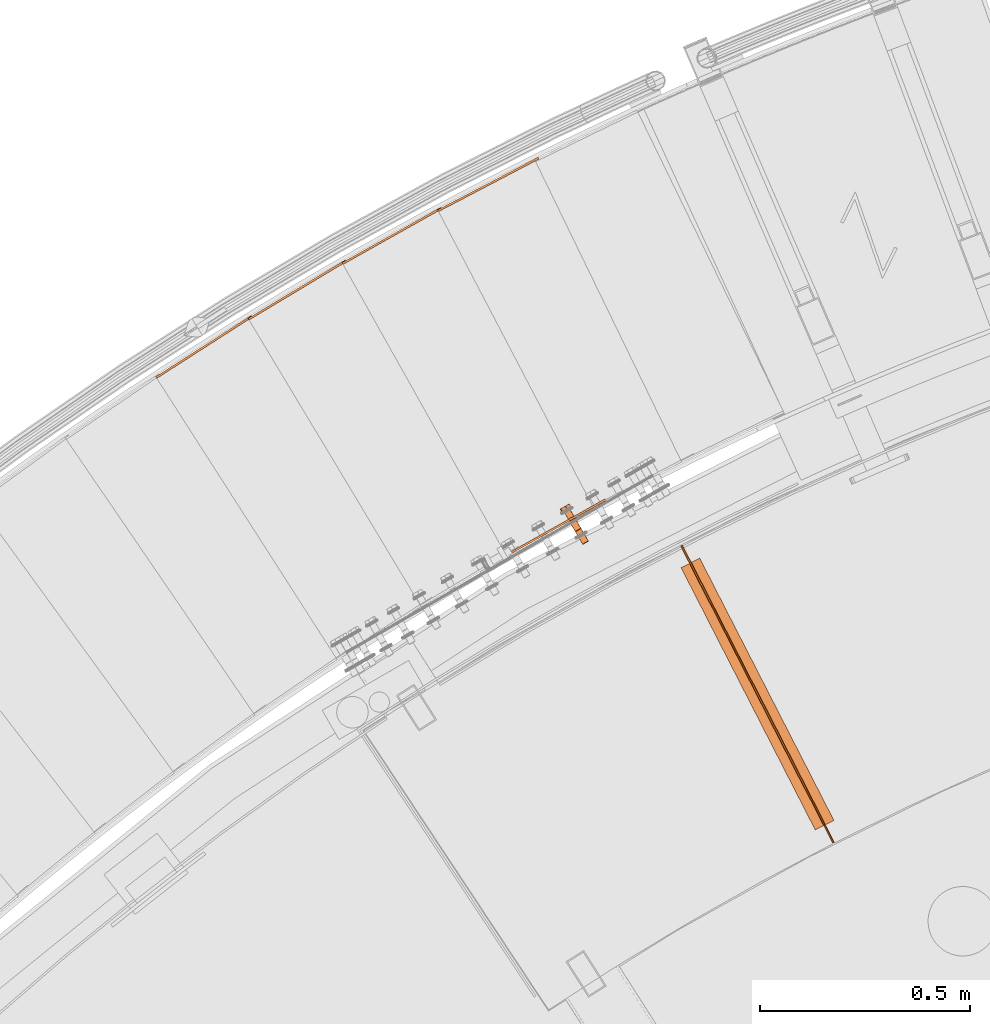
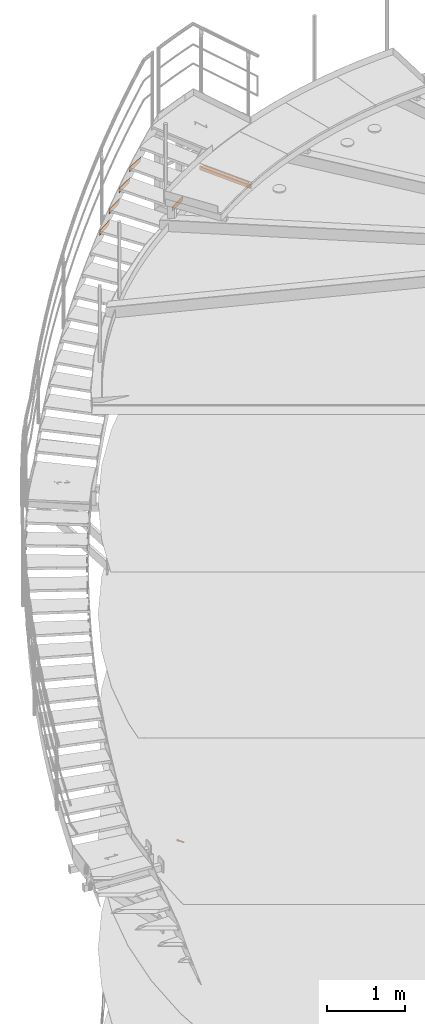
# One storey, part 80 of 126: 8 proxies.
"""IFC2X3 building model written with IfcOpenShell, lengths in millimetres."""

from ifc_helpers import new_model, si_unit, origin, origin_with_axes, place, context, project, spatial, faceted_brep, material, element, save


model = new_model("IFC2X3")

# Units and contexts
context_of_model_1 = context(None, 3, precision=0.1, world=origin())
context_of_model_2 = context(None, 3, precision=0.1, world=origin())
ifc_project = project(units=[si_unit("LENGTHUNIT", "METRE", prefix="MILLI"), si_unit("AREAUNIT", "SQUARE_METRE", prefix="CENTI"), si_unit("VOLUMEUNIT", "CUBIC_METRE", prefix="CENTI"), si_unit("MASSUNIT", "GRAM", prefix="KILO")], contexts=[context_of_model_1, context_of_model_2])

# Site, building, storey
site_placement = place(None, origin_with_axes())
site = spatial("IfcSite", under=ifc_project, at=site_placement, CompositionType="ELEMENT")
building_placement = place(site_placement, origin_with_axes())
building = spatial("IfcBuilding", under=site, at=building_placement, CompositionType="ELEMENT")
storey_placement = place(building_placement, origin_with_axes())
storey = spatial("IfcBuildingStorey", under=building, at=storey_placement, CompositionType="ELEMENT")

# Proxies
ifc_material_1 = material(Name="STAHL")
proxy_1_placement = place(storey_placement, origin_with_axes())
element("IfcBuildingElementProxy", 1, at=proxy_1_placement, inside=storey, material=ifc_material_1, Name="profile", context=context_of_model_2, shape_type="Brep", body=[
    faceted_brep([(4205.7, 14993.4, 508.9), (4207.3, 14994.3, 509.4), (4207.5, 14993.2, 510.4), (4206.1, 14992.4, 509.9), (4204.0, 14992.4, 508.8), (4204.7, 14991.5, 509.9), (4202.4, 14991.5, 509.2), (4203.2, 14990.7, 510.2), (4200.9, 14990.6, 510.1), (4201.9, 14990.0, 511.0), (4199.6, 14989.9, 511.3), (4200.8, 14989.3, 512.0), (4198.6, 14989.3, 512.8), (4200.0, 14988.8, 513.4), (4198.0, 14988.9, 514.6), (4199.4, 14988.5, 514.9), (4197.7, 14988.8, 516.5), (4199.2, 14988.4, 516.6), (4197.9, 14988.9, 518.5), (4199.3, 14988.5, 518.2), (4198.4, 14989.2, 520.3), (4199.8, 14988.7, 519.8), (4199.3, 14989.7, 521.9), (4200.6, 14989.2, 521.2), (4200.5, 14990.4, 523.2), (4201.6, 14989.8, 522.3), (4202.0, 14991.3, 524.2), (4202.9, 14990.5, 523.2), (4188.6, 15022.7, 509.9), (4188.2, 15023.7, 508.9), (4189.8, 15024.6, 509.4), (4190.0, 15023.5, 510.4), (4187.2, 15021.9, 509.9), (4186.5, 15022.7, 508.8), (4185.7, 15021.0, 510.2), (4184.9, 15021.8, 509.2), (4184.4, 15020.3, 511.0), (4183.4, 15020.9, 510.1), (4183.3, 15019.7, 512.0), (4182.1, 15020.2, 511.3), (4182.5, 15019.2, 513.4), (4181.1, 15019.6, 512.8), (4181.9, 15018.8, 514.9), (4180.5, 15019.3, 514.6), (4181.7, 15018.7, 516.6), (4180.2, 15019.1, 516.5), (4181.8, 15018.8, 518.2), (4180.4, 15019.2, 518.5), (4182.3, 15019.1, 519.8), (4180.9, 15019.5, 520.3), (4183.1, 15019.5, 521.2), (4181.8, 15020.0, 521.9), (4184.1, 15020.1, 522.3), (4183.0, 15020.7, 523.2), (4185.4, 15020.8, 523.2), (4184.5, 15021.6, 524.2), (4190.3, 15023.7, 509.4), (4191.8, 15024.5, 510.3), (4208.8, 14995.2, 510.3), (4203.6, 14992.2, 524.7), (4186.7, 15021.6, 524.7), (4185.0, 15020.6, 524.2), (4205.3, 14993.2, 524.7), (4188.3, 15022.5, 524.7), (4206.9, 14994.1, 524.3), (4190.0, 15023.5, 524.3), (4208.4, 14995.0, 523.5), (4191.5, 15024.3, 523.5), (4209.7, 14995.7, 522.3), (4192.7, 15025.1, 522.3), (4210.7, 14996.3, 520.7), (4193.7, 15025.7, 520.7), (4211.3, 14996.6, 518.9), (4194.4, 15026.0, 518.9), (4211.6, 14996.8, 517.0), (4194.6, 15026.2, 517.0), (4211.4, 14996.7, 515.1), (4194.5, 15026.1, 515.1), (4210.9, 14996.4, 513.3), (4193.9, 15025.8, 513.3), (4210.0, 14995.9, 511.7), (4193.0, 15025.2, 511.7), (4156.1, 15067.4, 523.2), (4154.9, 15066.7, 521.9), (4157.5, 15068.3, 524.2), (4161.2, 15070.4, 508.9), (4162.8, 15071.3, 509.4), (4159.6, 15069.4, 508.8), (4157.9, 15068.5, 509.2), (4156.4, 15067.6, 510.1), (4155.1, 15066.9, 511.3), (4154.2, 15066.3, 512.8), (4153.5, 15065.9, 514.6), (4153.3, 15065.8, 516.5), (4153.4, 15065.9, 518.5), (4154.0, 15066.2, 520.3), (4191.3, 15025.5, 510.3), (4164.3, 15072.2, 510.3), (4165.5, 15072.9, 511.7), (4192.5, 15026.2, 511.7), (4186.1, 15022.5, 524.7), (4159.2, 15069.2, 524.7), (4187.8, 15023.5, 524.7), (4160.8, 15070.2, 524.7), (4189.4, 15024.4, 524.3), (4162.5, 15071.1, 524.3), (4190.9, 15025.3, 523.5), (4164.0, 15072.0, 523.5), (4192.2, 15026.0, 522.3), (4165.2, 15072.7, 522.3), (4193.2, 15026.6, 520.7), (4166.2, 15073.3, 520.7), (4193.8, 15027.0, 518.9), (4166.9, 15073.7, 518.9), (4194.1, 15027.1, 517.0), (4167.1, 15073.8, 517.0), (4193.9, 15027.0, 515.1), (4167.0, 15073.7, 515.1), (4193.4, 15026.7, 513.3), (4166.4, 15073.4, 513.3), (4149.1, 15063.4, 511.5), (4158.6, 15068.9, 503.0), (4169.7, 15075.3, 508.3), (4171.3, 15076.2, 522.1), (4161.8, 15070.7, 530.5), (4150.7, 15064.3, 525.2), (4166.8, 15083.9, 522.1), (4165.2, 15083.6, 523.3), (4163.7, 15083.1, 524.5), (4162.6, 15082.7, 525.4), (4161.5, 15082.1, 526.3), (4160.3, 15081.3, 527.4), (4159.1, 15080.3, 528.6), (4158.2, 15079.4, 529.5), (4157.3, 15078.4, 530.5), (4152.5, 15076.8, 528.4), (4153.8, 15077.4, 529.0), (4155.5, 15078.0, 529.8), (4160.0, 15081.2, 527.4), (4158.3, 15080.3, 528.2), (4156.6, 15079.2, 528.7), (4154.7, 15078.2, 528.8), (4152.9, 15077.2, 528.5), (4151.2, 15076.2, 527.9), (4166.4, 15084.2, 520.5), (4166.1, 15084.4, 519.0), (4165.8, 15084.5, 517.1), (4165.5, 15084.4, 515.2), (4165.6, 15084.5, 517.3), (4165.3, 15084.3, 519.4), (4164.8, 15084.0, 521.4), (4164.0, 15083.5, 523.2), (4162.9, 15082.9, 524.9), (4159.2, 15080.8, 505.7), (4160.8, 15081.7, 506.7), (4162.2, 15082.5, 507.9), (4163.4, 15083.2, 509.5), (4164.4, 15083.8, 511.2), (4165.1, 15084.2, 513.2), (4165.3, 15084.0, 512.2), (4165.2, 15083.6, 510.3), (4165.3, 15083.0, 508.3), (4163.8, 15082.7, 507.7), (4162.4, 15082.2, 507.1), (4160.7, 15081.6, 506.4), (4165.4, 15084.3, 513.7), (4149.7, 15075.2, 527.1), (4148.3, 15074.1, 526.4), (4147.3, 15073.1, 525.8), (4146.2, 15072.0, 525.2), (4145.7, 15072.3, 523.2), (4145.3, 15072.5, 521.3), (4145.1, 15072.6, 519.8), (4144.9, 15072.5, 518.3), (4144.7, 15072.3, 516.5), (4144.6, 15072.0, 514.6), (4144.6, 15071.6, 513.1), (4144.6, 15071.1, 511.5), (4148.9, 15074.8, 507.3), (4150.4, 15075.7, 506.1), (4152.1, 15076.7, 505.3), (4153.8, 15077.7, 504.9), (4155.6, 15078.7, 504.8), (4157.4, 15079.8, 505.1), (4158.0, 15080.0, 505.1), (4156.8, 15079.2, 504.5), (4155.5, 15078.0, 503.8), (4154.2, 15076.6, 503.0), (4152.9, 15076.4, 504.0), (4151.6, 15076.0, 505.0), (4150.2, 15075.5, 506.1), (4144.8, 15072.5, 516.3), (4145.0, 15072.6, 514.2), (4145.6, 15072.9, 512.2), (4146.4, 15073.4, 510.3), (4147.5, 15074.0, 508.7), (4147.9, 15074.2, 508.2), (4146.9, 15073.4, 509.1), (4145.8, 15072.4, 510.3), (4149.6, 15075.2, 526.9), (4148.2, 15074.4, 525.6), (4146.9, 15073.7, 524.1), (4146.0, 15073.1, 522.3), (4145.3, 15072.7, 520.4), (4180.8, 15018.2, 516.5), (4180.9, 15018.3, 518.5), (4181.5, 15018.6, 520.3), (4182.4, 15019.1, 521.9), (4183.6, 15019.8, 523.2), (4192.9, 15025.2, 520.2), (4192.1, 15024.7, 521.5), (4190.9, 15024.0, 522.6), (4189.6, 15023.3, 523.3), (4188.2, 15022.5, 523.7), (4186.8, 15021.6, 523.6), (4191.2, 15024.2, 511.2), (4192.3, 15024.8, 512.3), (4193.1, 15025.3, 513.7), (4193.6, 15025.6, 515.3), (4193.7, 15025.6, 517.0), (4193.5, 15025.5, 518.6), (4188.7, 15022.8, 508.9), (4187.1, 15021.8, 508.8), (4185.4, 15020.9, 509.2), (4183.9, 15020.0, 510.1), (4182.6, 15019.3, 511.3), (4181.7, 15018.7, 512.8), (4181.0, 15018.3, 514.6), (4208.7, 14993.9, 511.2), (4209.8, 14994.5, 512.3), (4210.6, 14995.0, 513.7), (4211.1, 14995.2, 515.3), (4211.2, 14995.3, 517.0), (4211.0, 14995.2, 518.6), (4210.4, 14994.9, 520.2), (4209.6, 14994.4, 521.5), (4208.4, 14993.7, 522.6), (4207.1, 14993.0, 523.3), (4205.7, 14992.2, 523.7), (4204.3, 14991.3, 523.6)], [[[0, 1, 2, 3]], [[4, 0, 3, 5]], [[6, 4, 5, 7]], [[8, 6, 7, 9]], [[10, 8, 9, 11]], [[12, 10, 11, 13]], [[14, 12, 13, 15]], [[16, 14, 15, 17]], [[18, 16, 17, 19]], [[20, 18, 19, 21]], [[22, 20, 21, 23]], [[24, 22, 23, 25]], [[26, 24, 25, 27]], [[28, 29, 30, 31]], [[32, 33, 29, 28]], [[34, 35, 33, 32]], [[36, 37, 35, 34]], [[38, 39, 37, 36]], [[40, 41, 39, 38]], [[42, 43, 41, 40]], [[44, 45, 43, 42]], [[46, 47, 45, 44]], [[48, 49, 47, 46]], [[50, 51, 49, 48]], [[52, 53, 51, 50]], [[54, 55, 53, 52]], [[1, 56, 57, 58]], [[59, 60, 61, 26]], [[62, 63, 60, 59]], [[64, 65, 63, 62]], [[66, 67, 65, 64]], [[68, 69, 67, 66]], [[70, 71, 69, 68]], [[72, 73, 71, 70]], [[74, 75, 73, 72]], [[76, 77, 75, 74]], [[78, 79, 77, 76]], [[80, 81, 79, 78]], [[58, 57, 81, 80]], [[53, 82, 83, 51]], [[55, 84, 82, 53]], [[29, 85, 86, 30]], [[33, 87, 85, 29]], [[35, 88, 87, 33]], [[37, 89, 88, 35]], [[39, 90, 89, 37]], [[41, 91, 90, 39]], [[43, 92, 91, 41]], [[45, 93, 92, 43]], [[47, 94, 93, 45]], [[49, 95, 94, 47]], [[51, 83, 95, 49]], [[96, 30, 86, 97]], [[96, 97, 98, 99]], [[100, 101, 84, 55]], [[102, 103, 101, 100]], [[104, 105, 103, 102]], [[106, 107, 105, 104]], [[108, 109, 107, 106]], [[110, 111, 109, 108]], [[112, 113, 111, 110]], [[114, 115, 113, 112]], [[116, 117, 115, 114]], [[118, 119, 117, 116]], [[99, 98, 119, 118]], [[120, 121, 89, 90, 91, 92, 93, 94, 95, 83, 82, 84, 101, 103, 105, 107, 109, 111, 113, 115, 117, 119, 98, 97, 86, 85, 87, 88, 89, 121, 122, 123, 124, 125]], [[124, 123, 126, 127, 128, 129, 130, 131, 132, 133, 134]], [[135, 136, 137, 134, 133, 132, 131, 130, 138, 139, 140, 141, 142]], [[143, 135, 142]], [[129, 128, 127, 126, 144, 145, 146, 147, 148, 149, 150, 151, 152]], [[130, 129, 152]], [[153, 154, 155, 156, 157, 158, 159, 160, 161, 162, 163, 164]], [[165, 159, 158]], [[147, 165, 158]], [[125, 124, 134, 137, 136, 135, 143, 166, 167, 168, 169]], [[120, 125, 169, 170, 171, 172, 173, 174, 175, 176, 177]], [[178, 179, 180, 181, 182, 183, 184, 185, 186, 187, 188, 189, 190]], [[153, 184, 183]], [[177, 176, 175, 174, 173, 191, 192, 193, 194, 195, 196, 197, 198]], [[178, 196, 195]], [[169, 168, 167, 166, 143, 199, 200, 201, 202, 203, 171, 170]], [[172, 171, 203]], [[173, 172, 203]], [[120, 177, 198, 197, 196, 178, 190, 189, 188, 187, 121]], [[121, 187, 186, 185, 184, 153, 164, 163, 162, 161, 122]], [[122, 161, 160, 159, 165, 147, 146, 145, 144, 126, 123]], [[191, 173, 203, 202, 201, 200, 199, 143, 142, 141, 140, 139, 138, 130, 152, 151, 150, 149, 148, 147, 158, 157, 156, 155, 154, 153, 183, 182, 181, 180, 179, 178, 195, 194, 193, 192]], [[204, 205, 206, 207, 208, 61, 60, 63, 65, 67, 69, 209, 210, 211, 212, 213, 214, 54, 52, 50, 48, 46, 44, 42, 40, 38, 36, 34, 32, 28, 31, 215, 216, 217, 218, 219, 220, 209, 69, 71, 73, 75, 77, 79, 81, 57, 56, 221, 222, 223, 224, 225, 226, 227]], [[100, 55, 54, 214]], [[102, 100, 214, 213]], [[104, 102, 213, 212]], [[106, 104, 212, 211]], [[108, 106, 211, 210]], [[110, 108, 210, 209]], [[112, 110, 209, 220]], [[114, 112, 220, 219]], [[116, 114, 219, 218]], [[118, 116, 218, 217]], [[99, 118, 217, 216]], [[96, 99, 216, 215]], [[31, 30, 96, 215]], [[0, 221, 56, 1]], [[0, 4, 222, 221]], [[4, 6, 223, 222]], [[6, 8, 224, 223]], [[8, 10, 225, 224]], [[10, 12, 226, 225]], [[12, 14, 227, 226]], [[14, 16, 204, 227]], [[16, 18, 205, 204]], [[18, 20, 206, 205]], [[20, 22, 207, 206]], [[22, 24, 208, 207]], [[24, 26, 61, 208]], [[17, 15, 13, 11, 9, 7, 5, 3, 2, 228, 229, 230, 231, 232, 233, 234, 235, 236, 237, 238, 239, 27, 25, 23, 21, 19]], [[239, 59, 26, 27]], [[238, 62, 59, 239]], [[237, 64, 62, 238]], [[236, 66, 64, 237]], [[235, 68, 66, 236]], [[234, 70, 68, 235]], [[233, 72, 70, 234]], [[232, 74, 72, 233]], [[231, 76, 74, 232]], [[230, 78, 76, 231]], [[229, 80, 78, 230]], [[228, 58, 80, 229]], [[2, 1, 58, 228]]]),
])
proxy_2_placement = place(storey_placement, origin_with_axes())
element("IfcBuildingElementProxy", 2, at=proxy_2_placement, inside=storey, material=ifc_material_1, Name="profile", context=context_of_model_2, shape_type="Brep", body=[
    faceted_brep([(4795.6, 14281.0, 11051.2), (4795.6, 14281.0, 10981.2), (4434.9, 14986.1, 10981.2), (4434.9, 14986.1, 11051.2), (4792.1, 14279.2, 10981.2), (4431.3, 14984.2, 10981.2), (4792.1, 14279.2, 11051.2), (4431.3, 14984.2, 11051.2)], [[[0, 1, 2, 3]], [[1, 4, 5, 2]], [[4, 6, 7, 5]], [[6, 0, 3, 7]], [[1, 0, 6, 4]], [[7, 3, 2, 5]]]),
])
proxy_3_placement = place(storey_placement, origin_with_axes())
element("IfcBuildingElementProxy", 3, at=proxy_3_placement, inside=storey, material=ifc_material_1, Name="profile", context=context_of_model_2, shape_type="Brep", body=[
    faceted_brep([(4750.6, 14309.8, 11055.2), (4795.1, 14332.6, 11055.2), (4476.2, 14955.7, 11055.2), (4431.7, 14933.0, 11055.2), (4795.1, 14332.6, 11051.2), (4476.2, 14955.7, 11051.2), (4750.6, 14309.8, 11051.2), (4431.7, 14933.0, 11051.2)], [[[0, 1, 2, 3]], [[1, 4, 5, 2]], [[4, 6, 7, 5]], [[6, 0, 3, 7]], [[1, 0, 6, 4]], [[7, 3, 2, 5]]]),
])
ifc_material_2 = material(Name="S235JRG2")
proxy_4_placement = place(storey_placement, origin_with_axes())
element("IfcBuildingElementProxy", 4, at=proxy_4_placement, inside=storey, material=ifc_material_2, context=context_of_model_2, shape_type="Brep", body=[
    faceted_brep([(3183.4905, 15386.889, 10148.71), (3186.1898, 15382.68, 10148.71), (3186.1898, 15382.68, 10218.71), (3183.4905, 15386.889, 10218.71), (3410.7661, 15532.648, 10218.71), (3413.4653, 15528.439, 10218.71), (3413.4653, 15528.439, 10178.71), (3410.7661, 15532.648, 10178.71), (3385.5132, 15516.453, 10148.71), (3388.2125, 15512.244, 10148.71)], [[[0, 1, 2, 3]], [[4, 5, 6, 7]], [[0, 8, 9, 1]], [[1, 9, 6, 5, 2]], [[2, 5, 4, 3]], [[0, 3, 4, 7, 8]], [[6, 9, 8, 7]]]),
])
proxy_5_placement = place(storey_placement, origin_with_axes())
element("IfcBuildingElementProxy", 5, at=proxy_5_placement, inside=storey, material=ifc_material_2, context=context_of_model_2, shape_type="Brep", body=[
    faceted_brep([(3402.8544, 15525.604, 10321.87), (3405.4286, 15521.318, 10321.87), (3405.4286, 15521.318, 10391.87), (3402.8544, 15525.604, 10391.87), (3634.3217, 15664.611, 10391.87), (3636.8959, 15660.325, 10391.87), (3636.8959, 15660.325, 10351.87), (3634.3217, 15664.611, 10351.87), (3608.6032, 15649.166, 10321.87), (3611.1774, 15644.88, 10321.87)], [[[0, 1, 2, 3]], [[4, 5, 6, 7]], [[0, 8, 9, 1]], [[1, 9, 6, 5, 2]], [[2, 5, 4, 3]], [[0, 3, 4, 7, 8]], [[6, 9, 8, 7]]]),
])
proxy_6_placement = place(storey_placement, origin_with_axes())
element("IfcBuildingElementProxy", 6, at=proxy_6_placement, inside=storey, material=ifc_material_2, context=context_of_model_2, shape_type="Brep", body=[
    faceted_brep([(4015.2664, 14964.509, 10495.03), (4017.7133, 14960.149, 10495.03), (4017.7133, 14960.149, 10565.03), (4015.2664, 14964.509, 10565.03), (4250.7249, 15096.643, 10565.03), (4253.1718, 15092.282, 10565.03), (4253.1718, 15092.282, 10525.03), (4250.7249, 15096.643, 10525.03), (4224.5628, 15081.961, 10495.03), (4227.0097, 15077.601, 10495.03)], [[[0, 1, 2, 3]], [[4, 5, 6, 7]], [[0, 8, 9, 1]], [[1, 9, 6, 5, 2]], [[2, 5, 4, 3]], [[0, 3, 4, 7, 8]], [[6, 9, 8, 7]]]),
])
proxy_7_placement = place(storey_placement, origin_with_axes())
element("IfcBuildingElementProxy", 7, at=proxy_7_placement, inside=storey, material=ifc_material_2, context=context_of_model_2, shape_type="Brep", body=[
    faceted_brep([(3626.2062, 15657.803, 10495.03), (3628.6531, 15653.443, 10495.03), (3628.6531, 15653.443, 10565.03), (3626.2062, 15657.803, 10565.03), (3861.6647, 15789.937, 10565.03), (3864.1116, 15785.577, 10565.03), (3864.1116, 15785.577, 10525.03), (3861.6647, 15789.937, 10525.03), (3835.5026, 15775.255, 10495.03), (3837.9496, 15770.895, 10495.03)], [[[0, 1, 2, 3]], [[4, 5, 6, 7]], [[0, 8, 9, 1]], [[1, 9, 6, 5, 2]], [[2, 5, 4, 3]], [[0, 3, 4, 7, 8]], [[6, 9, 8, 7]]]),
])
proxy_8_placement = place(storey_placement, origin_with_axes())
element("IfcBuildingElementProxy", 8, at=proxy_8_placement, inside=storey, material=ifc_material_2, context=context_of_model_2, shape_type="Brep", body=[
    faceted_brep([(3853.3523, 15783.371, 10668.19), (3855.6698, 15778.941, 10668.19), (3855.6698, 15778.941, 10738.19), (3853.3523, 15783.371, 10738.19), (4092.5979, 15908.517, 10738.19), (4094.9154, 15904.087, 10738.19), (4094.9154, 15904.087, 10698.19), (4092.5979, 15908.517, 10698.19), (4066.0151, 15894.612, 10668.19), (4068.3326, 15890.182, 10668.19)], [[[0, 1, 2, 3]], [[4, 5, 6, 7]], [[0, 8, 9, 1]], [[1, 9, 6, 5, 2]], [[2, 5, 4, 3]], [[0, 3, 4, 7, 8]], [[6, 9, 8, 7]]]),
])

save(model, "model.ifc")
